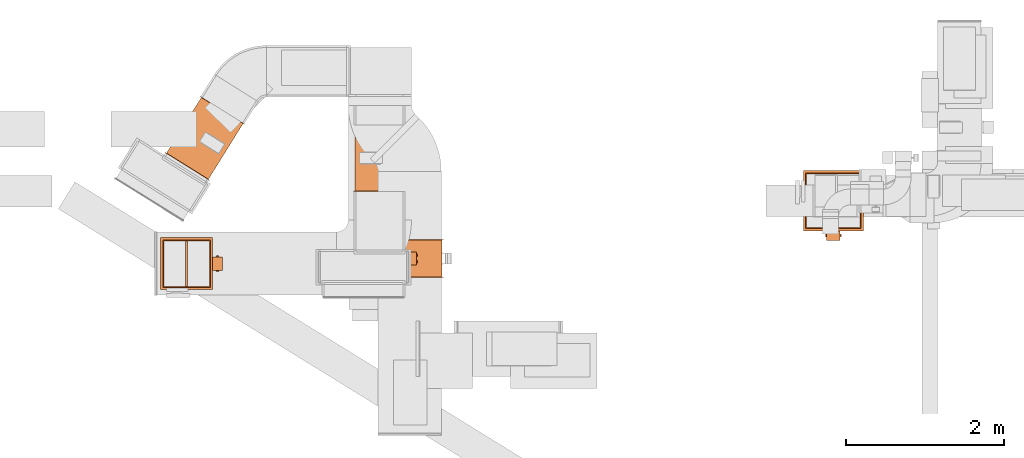
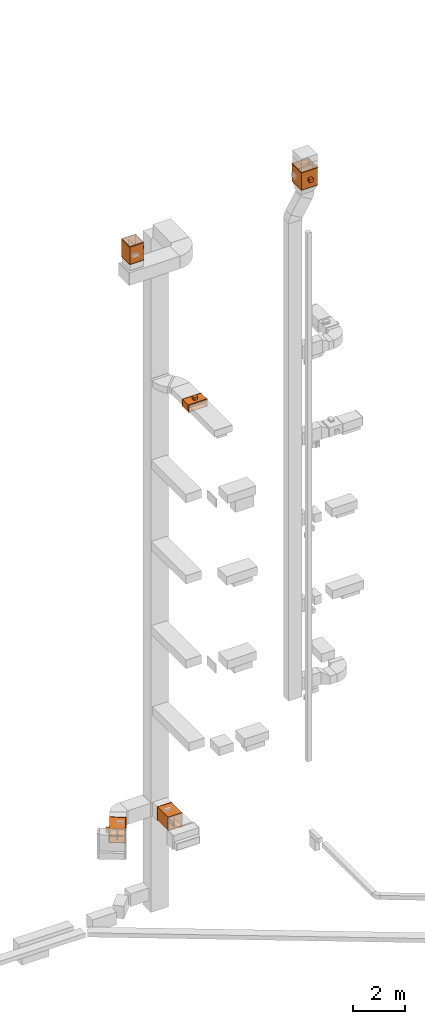
# One storey, part 19 of 29: 5 proxies.
"""IFC2X3 building model written with IfcOpenShell, lengths in millimetres."""

from ifc_helpers import new_model, entity, si_unit, converted_unit, derived_unit, direction, frame, frame_2d, origin, origin_2d_with_axis, place, context, subcontext, project, spatial, polyline, rectangle, hollow_circle, outline, extrude, source, transform, mapped, material, material_list, type_object, type_shapes, element, save


model = new_model("IFC2X3")

# Units and contexts
model_context = context("Model", 3, precision=0.01, world=origin(), true_north=direction((6.12303176911189e-17, 1.0)))
body_context = subcontext(model_context, "Body", "Model", "MODEL_VIEW")
ifc_project = project(units=[si_unit("LENGTHUNIT", "METRE", prefix="MILLI"), si_unit("AREAUNIT", "SQUARE_METRE"), si_unit("VOLUMEUNIT", "CUBIC_METRE"), converted_unit("PLANEANGLEUNIT", "DEGREE", entity("IfcRatioMeasure", 0.0174532925199433), si_unit("PLANEANGLEUNIT", "RADIAN"), dimensions=[0, 0, 0, 0, 0, 0, 0]), si_unit("MASSUNIT", "GRAM", prefix="KILO"), derived_unit("MASSDENSITYUNIT", [(si_unit("MASSUNIT", "GRAM", prefix="KILO"), 1), (si_unit("LENGTHUNIT", "METRE"), -3)]), derived_unit("MOMENTOFINERTIAUNIT", [(si_unit("LENGTHUNIT", "METRE"), 4)]), si_unit("TIMEUNIT", "SECOND"), si_unit("FREQUENCYUNIT", "HERTZ"), si_unit("THERMODYNAMICTEMPERATUREUNIT", "DEGREE_CELSIUS"), derived_unit("THERMALTRANSMITTANCEUNIT", [(si_unit("MASSUNIT", "GRAM", prefix="KILO"), 1), (si_unit("THERMODYNAMICTEMPERATUREUNIT", "KELVIN"), -1), (si_unit("TIMEUNIT", "SECOND"), -3)]), derived_unit("VOLUMETRICFLOWRATEUNIT", [(si_unit("LENGTHUNIT", "METRE"), 3), (si_unit("TIMEUNIT", "SECOND"), -1)]), derived_unit("MASSFLOWRATEUNIT", [(si_unit("MASSUNIT", "GRAM", prefix="KILO"), 1), (si_unit("TIMEUNIT", "SECOND"), -1)]), derived_unit("ROTATIONALFREQUENCYUNIT", [(si_unit("TIMEUNIT", "SECOND"), -1)]), si_unit("ELECTRICCURRENTUNIT", "AMPERE"), si_unit("ELECTRICVOLTAGEUNIT", "VOLT"), si_unit("POWERUNIT", "WATT"), si_unit("FORCEUNIT", "NEWTON", prefix="KILO"), si_unit("ILLUMINANCEUNIT", "LUX"), si_unit("LUMINOUSFLUXUNIT", "LUMEN"), si_unit("LUMINOUSINTENSITYUNIT", "CANDELA"), derived_unit("USERDEFINED", [(si_unit("MASSUNIT", "GRAM", prefix="KILO"), -1), (si_unit("LENGTHUNIT", "METRE"), -2), (si_unit("TIMEUNIT", "SECOND"), 3), (si_unit("LUMINOUSFLUXUNIT", "LUMEN"), 1)]), derived_unit("LINEARVELOCITYUNIT", [(si_unit("LENGTHUNIT", "METRE"), 1), (si_unit("TIMEUNIT", "SECOND"), -1)]), si_unit("PRESSUREUNIT", "PASCAL"), derived_unit("USERDEFINED", [(si_unit("LENGTHUNIT", "METRE"), -2), (si_unit("MASSUNIT", "GRAM", prefix="KILO"), 1), (si_unit("TIMEUNIT", "SECOND"), -2)]), derived_unit("LINEARFORCEUNIT", [(si_unit("MASSUNIT", "GRAM", prefix="KILO"), 1), (si_unit("LENGTHUNIT", "METRE"), 1), (si_unit("TIMEUNIT", "SECOND"), -2), (si_unit("LENGTHUNIT", "METRE"), -1)]), derived_unit("PLANARFORCEUNIT", [(si_unit("MASSUNIT", "GRAM", prefix="KILO"), 1), (si_unit("LENGTHUNIT", "METRE"), 1), (si_unit("TIMEUNIT", "SECOND"), -2), (si_unit("LENGTHUNIT", "METRE"), -2)])], contexts=[model_context])

# Site, building, storey
site_placement = place(None, frame((0.0, -0.00077364408347762, 0.0)))
site = spatial("IfcSite", under=ifc_project, at=site_placement, CompositionType="ELEMENT")
building_placement = place(site_placement, origin())
building = spatial("IfcBuilding", under=site, at=building_placement, CompositionType="ELEMENT")
storey_placement = place(building_placement, origin())
storey = spatial("IfcBuildingStorey", under=building, at=storey_placement, CompositionType="ELEMENT", Elevation=0.0)

# Proxies
ifc_material_1 = material()
ifc_material_2 = material()
ifc_material_list_1 = material_list([ifc_material_1, ifc_material_2])
ifc_material_list_2 = material_list([ifc_material_1, ifc_material_1, ifc_material_1, ifc_material_1, ifc_material_1, ifc_material_1, ifc_material_1, ifc_material_1, ifc_material_1, ifc_material_1, ifc_material_1, ifc_material_1, ifc_material_1, ifc_material_1, ifc_material_2, ifc_material_2, ifc_material_2, ifc_material_2, ifc_material_2])
building_element_proxy_type_1 = type_object("IfcBuildingElementProxyType", PredefinedType="NOTDEFINED", material=ifc_material_list_2)
shared_shape_1 = source(origin(), body_context, "Body", "SweptSolid", [
    extrude(rectangle(XDim=1.5, YDim=170.0, at=frame_2d((3.3806291099836e-14, 0.0), x_axis=(1.0, 0.0))), frame((0.0, -312.750000000076, -62.0), z_axis=(0.0, 0.0, 1.0), x_axis=(0.0, 1.0, 0.0)), (0.0, 0.0, 1.0), 123.000000000001),
    extrude(outline(polyline([(-5.0073597414186, -14.1635201826924), (-3.50735974141928, -14.1635201826924), (-3.50735974141928, 6.32704036539947), (8.51471948283787, 6.3270403654089), (8.51471948283787, 7.83647981728816), (-5.0073597414186, 7.83647981728816), (-5.0073597414186, -14.1635201826924)])), frame((-72.1635201826895, -321.99264025864, -62.0), z_axis=(0.0, 0.0, 1.0), x_axis=(0.0, 1.0, 0.0)), (0.0, 0.0, 1.0), 25.0),
    extrude(outline(polyline([(-13.8364798173165, -5.0073597414188), (7.67295963462824, -5.0073597414188), (7.67295963462824, 8.51471948283767), (6.16352018269341, 8.51471948283767), (6.16352018268311, -3.50735974141901), (-13.8364798173165, -3.50735974141901), (-13.8364798173165, -5.0073597414188)])), frame((72.3270403653872, -321.99264025864, -62.0)), (0.0, 0.0, 1.0), 25.0000000000005),
    extrude(outline(polyline([(-5.00735974141853, -14.163520182702), (-3.50735974141955, -14.163520182702), (-3.50735974141955, 6.3270403653898), (8.51471948283794, 6.32704036538944), (8.51471948283794, 7.83647981731237), (-5.00735974141853, 7.83647981731237), (-5.00735974141853, -14.163520182702)])), frame((-72.1635201826969, -321.99264025864, 36.0), z_axis=(0.0, 0.0, 1.0), x_axis=(0.0, 1.0, 0.0)), (0.0, 0.0, 1.0), 25.0),
    extrude(outline(polyline([(-9.39005042212508, -16.0890911238457), (8.81483867126946, -16.0890911238457), (18.3453872917851, -0.0836606621788136), (9.67104681890716, 15.9217697994894), (-8.95533686966038, 16.1727517860241), (-18.4858854901761, 0.16732132435702), (-9.39005042212508, -16.0890911238457)])), frame((-39.8364798173101, -389.500000000062, 88.0), z_axis=(0.0, 0.0, 1.0), x_axis=(-0.859210135894937, -0.511622851693906, 0.0)), (0.0, 0.0, 1.0), 10.0),
    extrude(outline(polyline([(-9.25778653449053, -16.0349566433433), (9.25778653447247, -16.0349566433433), (18.5155730689534, 0.0), (9.25778653447179, 16.0349566433542), (-9.25778653446304, 16.0349566433379), (-18.515573068944, 0.0), (-9.25778653449053, -16.0349566433433)])), frame((40.0, -389.500000000058, 88.0), z_axis=(0.0, 0.0, 1.0), x_axis=(-0.866025403784451, -0.499999999999978, 0.0)), (0.0, 0.0, 1.0), 10.0),
    extrude(hollow_circle(Radius=15.0, WallThickness=6.97527274236894, at=frame_2d((3.55257043274876e-28, -6.76791955811494e-14), x_axis=(1.0, 0.0))), frame((40.0, -389.500000000057, 86.0)), (0.0, 0.0, 1.0), 14.0),
    extrude(hollow_circle(Radius=15.0, WallThickness=7.0, at=frame_2d((1.00544105397778e-41, -6.76791955811495e-14), x_axis=(1.0, 0.0))), frame((-40.0, -389.500000000057, 86.0)), (0.0, 0.0, 1.0), 14.0),
    extrude(outline(polyline([(-13.8364798173041, -5.0073597414186), (7.67295963460837, -5.0073597414186), (7.67295963460837, 8.51471948283787), (6.16352018269594, 8.51471948283787), (6.1635201826955, -3.50735974141934), (-13.8364798173041, -3.50735974141934), (-13.8364798173041, -5.0073597414186)])), frame((72.3270403653869, -321.99264025864, 36.0)), (0.0, 0.0, 1.0), 25.0),
    extrude(outline(polyline([(-9.39005042212339, -16.0890911238459), (8.81483867127267, -16.0890911238459), (18.345387291786, -0.0836606621774473), (9.67104681890318, 15.9217697994909), (-8.95533686966255, 16.1727517860234), (-18.4858854901759, 0.167321324354905), (-9.39005042212339, -16.0890911238459)])), frame((-39.8364798173151, -389.500000000064, -98.0), z_axis=(0.0, 0.0, 1.0), x_axis=(-0.859210135895013, -0.511622851693778, 0.0)), (0.0, 0.0, 1.0), 9.99999999999999),
    extrude(outline(polyline([(-9.25778653449118, -16.0349566433429), (9.25778653447143, -16.0349566433429), (18.5155730689525, 0.0), (9.25778653447021, 16.0349566433551), (-9.25778653446091, 16.0349566433369), (-18.5155730689421, 0.0), (-9.25778653449118, -16.0349566433429)])), frame((40.0, -389.500000000059, -98.0), z_axis=(0.0, 0.0, 1.0), x_axis=(-0.866025403784445, -0.499999999999988, 0.0)), (0.0, 0.0, 1.0), 9.99999999999999),
    extrude(hollow_circle(Radius=15.0, WallThickness=6.97527274236894, at=frame_2d((1.00544105397778e-41, -6.76791955811495e-14), x_axis=(1.0, 0.0))), frame((40.0, -389.500000000059, -100.0)), (0.0, 0.0, 1.0), 14.0000000000002),
    extrude(hollow_circle(Radius=15.0, WallThickness=7.0, at=frame_2d((1.00544105397778e-41, -6.76791955811495e-14), x_axis=(1.0, 0.0))), frame((-40.0, -389.500000000059, -100.0)), (0.0, 0.0, 1.0), 14.0000000000002),
    extrude(rectangle(XDim=127.0, YDim=159.999999999992, at=frame_2d((0.0, 1.4210854715202e-14), x_axis=(1.0, 0.0))), frame((0.0, -390.500000000059, -86.0), z_axis=(0.0, 0.0, 1.0), x_axis=(0.0, 1.0, 0.0)), (0.0, 0.0, 1.0), 171.999999999999),
    extrude(outline(polyline([(-312.0, -312.0), (312.0, -312.0), (312.0, 312.0), (-312.0, 312.0), (-312.0, -312.0)]), holes=[polyline([(300.0, 300.0), (300.0, -300.0), (-300.0, -300.0), (-300.0, 300.0), (300.0, 300.0)])]), frame((-420.0, 0.0, 0.0), z_axis=(1.0, 0.0, 0.0), x_axis=(0.0, -1.0, 0.0)), (0.0, 0.0, 1.0), 840.0),
    extrude(rectangle(XDim=596.0, YDim=24.0000000000003, at=origin_2d_with_axis()), frame((0.0, 0.0, -288.0), z_axis=(0.0, 0.0, 1.0), x_axis=(-1.0, 0.0, 0.0)), (0.0, 0.0, 1.0), 576.000000000017),
    extrude(outline(polyline([(-330.0, -330.0), (330.0, -330.0), (330.0, 330.0), (-330.0, 330.0), (-330.0, -330.0)]), holes=[polyline([(-300.0, -300.0), (-300.0, 300.0), (300.0, 300.0), (300.0, -300.0), (-300.0, -300.0)])]), frame((415.0, 0.0, 0.0), z_axis=(1.0, 0.0, 0.0), x_axis=(0.0, -1.0, 0.0)), (0.0, 0.0, 1.0), 5.00000000000326),
    extrude(outline(polyline([(-330.0, -330.0), (330.0, -330.0), (330.0, 330.0), (-330.0, 330.0), (-330.0, -330.0)]), holes=[polyline([(-300.0, -300.0), (-300.0, 300.0), (300.0, 300.0), (300.0, -300.0), (-300.0, -300.0)])]), frame((-420.0, 0.0, 0.0), z_axis=(1.0, 0.0, 0.0), x_axis=(0.0, -1.0, 0.0)), (0.0, 0.0, 1.0), 4.99999999999995),
    extrude(outline(polyline([(-300.0, -300.0), (300.0, -300.0), (300.0, 300.0), (-300.0, 300.0), (-300.0, -300.0)]), holes=[polyline([(288.0, -288.0), (-288.0, -288.0), (-288.0, 288.0), (288.0, 288.0), (288.0, -288.0)])]), frame((-6.0, 0.0, 0.0), z_axis=(1.0, 0.0, 0.0), x_axis=(0.0, 0.0, -1.0)), (0.0, 0.0, 1.0), 12.0),
])
type_shapes(building_element_proxy_type_1, [shared_shape_1])
proxy_1_placement = place(storey_placement, frame((4538.73846384672, 15211.3442907761, 2800.0), z_axis=(0.0, 0.0, 1.0), x_axis=(0.0, 1.0, 0.0)))
element("IfcBuildingElementProxy", 1, at=proxy_1_placement, inside=storey, type_object=building_element_proxy_type_1, material=ifc_material_list_1, context=body_context, shape_type="MappedRepresentation", body=[
    mapped(shared_shape_1, transform((0.0, 0.0, 0.0), scale=1.0)),
])
ifc_material_list_3 = material_list([ifc_material_1, ifc_material_2])
proxy_2_placement = place(storey_placement, frame((2329.12093080707, 15461.7090414809, 2785.0), z_axis=(0.0, 0.0, 1.0), x_axis=(-0.529919264328233, -0.848048096097046, 0.0)))
element("IfcBuildingElementProxy", 2, at=proxy_2_placement, inside=storey, type_object=building_element_proxy_type_1, material=ifc_material_list_3, context=body_context, shape_type="MappedRepresentation", body=[
    mapped(shared_shape_1, transform((0.0, 0.0, 0.0), scale=1.0)),
])
ifc_material_list_4 = material_list([ifc_material_1, ifc_material_2])
proxy_3_placement = place(storey_placement, frame((2099.0, 13877.5681314502, 31335.0), z_axis=(0.0, -1.0, 0.0), x_axis=(0.0, 0.0, 1.0)))
element("IfcBuildingElementProxy", 3, at=proxy_3_placement, inside=storey, type_object=building_element_proxy_type_1, material=ifc_material_list_4, context=body_context, shape_type="MappedRepresentation", body=[
    mapped(shared_shape_1, transform((0.0, 0.0, 0.0), scale=1.0)),
])
ifc_material_list_5 = material_list([ifc_material_1, ifc_material_2])
ifc_material_list_6 = material_list([ifc_material_1, ifc_material_1, ifc_material_1, ifc_material_1, ifc_material_1, ifc_material_1, ifc_material_1, ifc_material_1, ifc_material_1, ifc_material_1, ifc_material_1, ifc_material_1, ifc_material_1, ifc_material_1, ifc_material_2, ifc_material_2, ifc_material_2, ifc_material_2, ifc_material_2])
building_element_proxy_type_2 = type_object("IfcBuildingElementProxyType", PredefinedType="NOTDEFINED", material=ifc_material_list_6)
shared_shape_2 = source(origin(), body_context, "Body", "SweptSolid", [
    extrude(rectangle(XDim=1.5, YDim=170.0, at=origin_2d_with_axis()), frame((0.0, -162.750000000076, -62.0), z_axis=(0.0, 0.0, 1.0), x_axis=(0.0, 1.0, 0.0)), (0.0, 0.0, 1.0), 123.000000000001),
    extrude(outline(polyline([(-5.0073597414186, -14.1635201826924), (-3.50735974141924, -14.1635201826924), (-3.50735974141928, 6.32704036539947), (8.51471948283784, 6.3270403654089), (8.51471948283784, 7.83647981728816), (-5.0073597414186, 7.83647981728816), (-5.0073597414186, -14.1635201826924)])), frame((-72.1635201826895, -171.99264025864, -62.0), z_axis=(0.0, 0.0, 1.0), x_axis=(0.0, 1.0, 0.0)), (0.0, 0.0, 1.0), 25.0),
    extrude(outline(polyline([(-13.8364798173165, -5.0073597414188), (7.67295963462824, -5.0073597414188), (7.67295963462824, 8.51471948283767), (6.16352018269341, 8.51471948283767), (6.16352018268311, -3.50735974141897), (-13.8364798173165, -3.50735974141897), (-13.8364798173165, -5.0073597414188)])), frame((72.3270403653872, -171.99264025864, -62.0)), (0.0, 0.0, 1.0), 25.0000000000005),
    extrude(outline(polyline([(-5.00735974141846, -14.163520182702), (-3.50735974141948, -14.163520182702), (-3.50735974141948, 6.3270403653898), (8.51471948283798, 6.32704036538944), (8.51471948283798, 7.83647981731237), (-5.00735974141846, 7.83647981731237), (-5.00735974141846, -14.163520182702)])), frame((-72.1635201826969, -171.99264025864, 36.0), z_axis=(0.0, 0.0, 1.0), x_axis=(0.0, 1.0, 0.0)), (0.0, 0.0, 1.0), 25.0),
    extrude(outline(polyline([(-9.3900504221251, -16.0890911238458), (8.81483867126944, -16.0890911238458), (18.3453872917851, -0.0836606621788432), (9.67104681890714, 15.9217697994894), (-8.95533686966039, 16.172751786024), (-18.4858854901761, 0.167321324356992), (-9.3900504221251, -16.0890911238458)])), frame((-39.8364798173101, -239.500000000062, 88.0), z_axis=(0.0, 0.0, 1.0), x_axis=(-0.859210135894937, -0.511622851693906, 0.0)), (0.0, 0.0, 1.0), 10.0),
    extrude(outline(polyline([(-9.25778653449057, -16.0349566433433), (9.25778653447244, -16.0349566433433), (18.5155730689534, 0.0), (9.25778653447179, 16.0349566433541), (-9.25778653446303, 16.0349566433379), (-18.515573068944, 0.0), (-9.25778653449057, -16.0349566433433)])), frame((40.0, -239.500000000058, 88.0), z_axis=(0.0, 0.0, 1.0), x_axis=(-0.86602540378445, -0.499999999999979, 0.0)), (0.0, 0.0, 1.0), 10.0),
    extrude(hollow_circle(Radius=15.0, WallThickness=6.97527274236894, at=frame_2d((3.55257043274876e-28, -6.76791955811494e-14), x_axis=(1.0, 0.0))), frame((40.0, -239.500000000057, 86.0)), (0.0, 0.0, 1.0), 14.0),
    extrude(hollow_circle(Radius=15.0, WallThickness=7.0, at=frame_2d((1.00544105397778e-41, -6.76791955811495e-14), x_axis=(1.0, 0.0))), frame((-40.0, -239.500000000057, 86.0)), (0.0, 0.0, 1.0), 14.0),
    extrude(outline(polyline([(-13.8364798173041, -5.0073597414186), (7.67295963460837, -5.0073597414186), (7.67295963460837, 8.51471948283787), (6.16352018269594, 8.51471948283787), (6.1635201826955, -3.50735974141934), (-13.8364798173041, -3.50735974141934), (-13.8364798173041, -5.0073597414186)])), frame((72.3270403653869, -171.99264025864, 36.0)), (0.0, 0.0, 1.0), 25.0),
    extrude(outline(polyline([(-9.39005042212341, -16.0890911238458), (8.81483867127266, -16.0890911238458), (18.3453872917859, -0.0836606621775066), (9.67104681890322, 15.9217697994909), (-8.95533686966253, 16.1727517860234), (-18.4858854901759, 0.167321324354935), (-9.39005042212341, -16.0890911238458)])), frame((-39.8364798173151, -239.500000000064, -98.0), z_axis=(0.0, 0.0, 1.0), x_axis=(-0.859210135895012, -0.511622851693779, 0.0)), (0.0, 0.0, 1.0), 9.99999999999999),
    extrude(outline(polyline([(-9.25778653449123, -16.0349566433429), (9.2577865344714, -16.0349566433429), (18.5155730689525, 0.0), (9.25778653447022, 16.034956643355), (-9.25778653446088, 16.0349566433369), (-18.5155730689421, 0.0), (-9.25778653449123, -16.0349566433429)])), frame((40.0, -239.500000000059, -98.0), z_axis=(0.0, 0.0, 1.0), x_axis=(-0.866025403784445, -0.49999999999999, 0.0)), (0.0, 0.0, 1.0), 9.99999999999999),
    extrude(hollow_circle(Radius=15.0, WallThickness=6.97527274236894, at=frame_2d((-3.55257043274856e-28, -6.76791955811497e-14), x_axis=(1.0, 0.0))), frame((40.0, -239.500000000059, -100.0)), (0.0, 0.0, 1.0), 14.0000000000002),
    extrude(hollow_circle(Radius=15.0, WallThickness=7.0, at=frame_2d((1.00544105397778e-41, -6.76791955811495e-14), x_axis=(1.0, 0.0))), frame((-40.0, -239.500000000059, -100.0)), (0.0, 0.0, 1.0), 14.0000000000002),
    extrude(rectangle(XDim=127.0, YDim=159.999999999992, at=frame_2d((0.0, 1.4210854715202e-14), x_axis=(1.0, 0.0))), frame((0.0, -240.500000000059, -86.0), z_axis=(0.0, 0.0, 1.0), x_axis=(0.0, 1.0, 0.0)), (0.0, 0.0, 1.0), 171.999999999999),
    extrude(outline(polyline([(-162.0, -412.0), (162.0, -412.0), (162.0, 412.0), (-162.0, 412.0), (-162.0, -412.0)]), holes=[polyline([(150.0, 400.0), (150.0, -400.0), (-150.0, -400.0), (-150.0, 400.0), (150.0, 400.0)])]), frame((-240.0, 0.0, 0.0), z_axis=(1.0, 0.0, 0.0), x_axis=(0.0, -1.0, 0.0)), (0.0, 0.0, 1.0), 480.0),
    extrude(rectangle(XDim=296.0, YDim=24.0000000000003, at=origin_2d_with_axis()), frame((0.0, 0.0, -388.0), z_axis=(0.0, 0.0, 1.0), x_axis=(-1.0, 0.0, 0.0)), (0.0, 0.0, 1.0), 776.000000000017),
    extrude(outline(polyline([(-180.0, -430.0), (180.0, -430.0), (180.0, 430.0), (-180.0, 430.0), (-180.0, -430.0)]), holes=[polyline([(-150.0, -400.0), (-150.0, 400.0), (150.0, 400.0), (150.0, -400.0), (-150.0, -400.0)])]), frame((235.0, 0.0, 0.0), z_axis=(1.0, 0.0, 0.0), x_axis=(0.0, -1.0, 0.0)), (0.0, 0.0, 1.0), 5.00000000000319),
    extrude(outline(polyline([(-180.0, -430.0), (180.0, -430.0), (180.0, 430.0), (-180.0, 430.0), (-180.0, -430.0)]), holes=[polyline([(-150.0, -400.0), (-150.0, 400.0), (150.0, 400.0), (150.0, -400.0), (-150.0, -400.0)])]), frame((-240.0, 0.0, 0.0), z_axis=(1.0, 0.0, 0.0), x_axis=(0.0, -1.0, 0.0)), (0.0, 0.0, 1.0), 4.99999999999991),
    extrude(outline(polyline([(-400.0, -150.0), (400.0, -150.0), (400.0, 150.0), (-400.0, 150.0), (-400.0, -150.0)]), holes=[polyline([(388.0, -138.0), (-388.0, -138.0), (-388.0, 138.0), (388.0, 138.0), (388.0, -138.0)])]), frame((-6.0, 0.0, 0.0), z_axis=(1.0, 0.0, 0.0), x_axis=(0.0, 0.0, -1.0)), (0.0, 0.0, 1.0), 12.0),
])
type_shapes(building_element_proxy_type_2, [shared_shape_2])
proxy_4_placement = place(storey_placement, frame((4919.66175990126, 13941.6087465571, 23050.0), z_axis=(1.0, 0.0, 0.0), x_axis=(0.0, -1.0, 0.0)))
element("IfcBuildingElementProxy", 4, at=proxy_4_placement, inside=storey, type_object=building_element_proxy_type_2, material=ifc_material_list_5, context=body_context, shape_type="MappedRepresentation", body=[
    mapped(shared_shape_2, transform((0.0, 0.0, 0.0), scale=1.0)),
])
ifc_material_list_7 = material_list([ifc_material_1, ifc_material_2])
ifc_material_list_8 = material_list([ifc_material_1, ifc_material_1, ifc_material_1, ifc_material_1, ifc_material_1, ifc_material_1, ifc_material_1, ifc_material_1, ifc_material_1, ifc_material_1, ifc_material_1, ifc_material_1, ifc_material_1, ifc_material_1, ifc_material_2, ifc_material_2, ifc_material_2, ifc_material_2, ifc_material_2])
building_element_proxy_type_3 = type_object("IfcBuildingElementProxyType", PredefinedType="NOTDEFINED", material=ifc_material_list_8)
shared_shape_3 = source(origin(), body_context, "Body", "SweptSolid", [
    extrude(rectangle(XDim=1.5, YDim=170.0, at=frame_2d((3.3806291099836e-14, 0.0), x_axis=(1.0, 0.0))), frame((0.0, -362.750000000075, -62.0), z_axis=(0.0, 0.0, 1.0), x_axis=(0.0, 1.0, 0.0)), (0.0, 0.0, 1.0), 123.000000000001),
    extrude(outline(polyline([(-5.00735974141867, -14.1635201826924), (-3.50735974141934, -14.1635201826924), (-3.50735974141934, 6.32704036539947), (8.51471948283781, 6.3270403654089), (8.51471948283781, 7.83647981728816), (-5.00735974141867, 7.83647981728816), (-5.00735974141867, -14.1635201826924)])), frame((-72.1635201826895, -371.99264025864, -62.0), z_axis=(0.0, 0.0, 1.0), x_axis=(0.0, 1.0, 0.0)), (0.0, 0.0, 1.0), 25.0),
    extrude(outline(polyline([(-13.8364798173165, -5.0073597414188), (7.67295963462824, -5.0073597414188), (7.67295963462824, 8.51471948283767), (6.16352018269341, 8.51471948283767), (6.16352018268311, -3.50735974141901), (-13.8364798173165, -3.50735974141901), (-13.8364798173165, -5.0073597414188)])), frame((72.3270403653872, -371.99264025864, -62.0)), (0.0, 0.0, 1.0), 25.0000000000005),
    extrude(outline(polyline([(-5.00735974141853, -14.163520182702), (-3.50735974141955, -14.163520182702), (-3.50735974141955, 6.3270403653898), (8.51471948283794, 6.32704036538944), (8.51471948283794, 7.83647981731237), (-5.00735974141853, 7.83647981731237), (-5.00735974141853, -14.163520182702)])), frame((-72.1635201826969, -371.99264025864, 36.0), z_axis=(0.0, 0.0, 1.0), x_axis=(0.0, 1.0, 0.0)), (0.0, 0.0, 1.0), 25.0),
    extrude(outline(polyline([(-9.39005042212508, -16.0890911238457), (8.81483867126946, -16.0890911238457), (18.3453872917851, -0.0836606621788136), (9.67104681890716, 15.9217697994894), (-8.95533686966038, 16.1727517860241), (-18.4858854901761, 0.16732132435702), (-9.39005042212508, -16.0890911238457)])), frame((-39.8364798173101, -439.500000000061, 88.0), z_axis=(0.0, 0.0, 1.0), x_axis=(-0.859210135894937, -0.511622851693906, 0.0)), (0.0, 0.0, 1.0), 9.99999999999999),
    extrude(outline(polyline([(-9.25778653449053, -16.0349566433433), (9.25778653447247, -16.0349566433433), (18.5155730689534, 0.0), (9.25778653447179, 16.0349566433542), (-9.25778653446304, 16.0349566433379), (-18.515573068944, 0.0), (-9.25778653449053, -16.0349566433433)])), frame((40.0, -439.500000000057, 88.0), z_axis=(0.0, 0.0, 1.0), x_axis=(-0.866025403784451, -0.499999999999978, 0.0)), (0.0, 0.0, 1.0), 9.99999999999999),
    extrude(hollow_circle(Radius=15.0, WallThickness=6.97527274236894, at=frame_2d((3.55257043274876e-28, -6.76791955811494e-14), x_axis=(1.0, 0.0))), frame((40.0, -439.500000000057, 86.0)), (0.0, 0.0, 1.0), 14.0),
    extrude(hollow_circle(Radius=15.0, WallThickness=7.0, at=frame_2d((1.00544105397778e-41, -6.76791955811495e-14), x_axis=(1.0, 0.0))), frame((-40.0, -439.500000000057, 86.0)), (0.0, 0.0, 1.0), 14.0),
    extrude(outline(polyline([(-13.8364798173041, -5.0073597414186), (7.67295963460837, -5.0073597414186), (7.67295963460837, 8.51471948283787), (6.16352018269594, 8.51471948283787), (6.1635201826955, -3.50735974141934), (-13.8364798173041, -3.50735974141934), (-13.8364798173041, -5.0073597414186)])), frame((72.3270403653869, -371.992640258639, 36.0)), (0.0, 0.0, 1.0), 25.0),
    extrude(outline(polyline([(-9.39005042212335, -16.0890911238458), (8.8148386712727, -16.0890911238458), (18.345387291786, -0.0836606621773892), (9.67104681890321, 15.9217697994909), (-8.95533686966252, 16.1727517860234), (-18.4858854901758, 0.167321324354963), (-9.39005042212335, -16.0890911238458)])), frame((-39.8364798173151, -439.500000000063, -98.0), z_axis=(0.0, 0.0, 1.0), x_axis=(-0.859210135895013, -0.511622851693778, 0.0)), (0.0, 0.0, 1.0), 9.99999999999999),
    extrude(outline(polyline([(-9.25778653449122, -16.034956643343), (9.25778653447139, -16.034956643343), (18.5155730689525, 0.0), (9.25778653447017, 16.034956643355), (-9.25778653446094, 16.0349566433368), (-18.5155730689421, 0.0), (-9.25778653449122, -16.034956643343)])), frame((40.0, -439.500000000059, -98.0), z_axis=(0.0, 0.0, 1.0), x_axis=(-0.866025403784445, -0.499999999999988, 0.0)), (0.0, 0.0, 1.0), 9.99999999999999),
    extrude(hollow_circle(Radius=15.0, WallThickness=6.97527274236894, at=frame_2d((-3.55257043274856e-28, -6.76791955811497e-14), x_axis=(1.0, 0.0))), frame((40.0, -439.500000000059, -100.0)), (0.0, 0.0, 1.0), 14.0000000000002),
    extrude(hollow_circle(Radius=15.0, WallThickness=7.0, at=frame_2d((1.00544105397778e-41, -6.76791955811495e-14), x_axis=(1.0, 0.0))), frame((-40.0, -439.500000000059, -100.0)), (0.0, 0.0, 1.0), 14.0000000000002),
    extrude(rectangle(XDim=127.0, YDim=159.999999999992, at=frame_2d((0.0, 1.4210854715202e-14), x_axis=(1.0, 0.0))), frame((0.0, -440.500000000059, -86.0), z_axis=(0.0, 0.0, 1.0), x_axis=(0.0, 1.0, 0.0)), (0.0, 0.0, 1.0), 171.999999999999),
    extrude(outline(polyline([(-362.0, -362.0), (362.0, -362.0), (362.0, 362.0), (-362.0, 362.0), (-362.0, -362.0)]), holes=[polyline([(350.0, 350.0), (350.0, -350.0), (-350.0, -350.0), (-350.0, 350.0), (350.0, 350.0)])]), frame((-420.0, 0.0, 0.0), z_axis=(1.0, 0.0, 0.0), x_axis=(0.0, -1.0, 0.0)), (0.0, 0.0, 1.0), 840.0),
    extrude(rectangle(XDim=696.0, YDim=24.0000000000003, at=origin_2d_with_axis()), frame((0.0, 0.0, -338.0), z_axis=(0.0, 0.0, 1.0), x_axis=(-1.0, 0.0, 0.0)), (0.0, 0.0, 1.0), 676.000000000017),
    extrude(outline(polyline([(-380.0, -380.0), (380.0, -380.0), (380.0, 380.0), (-380.0, 380.0), (-380.0, -380.0)]), holes=[polyline([(-350.0, -350.0), (-350.0, 350.0), (350.0, 350.0), (350.0, -350.0), (-350.0, -350.0)])]), frame((415.0, 0.0, 0.0), z_axis=(1.0, 0.0, 0.0), x_axis=(0.0, -1.0, 0.0)), (0.0, 0.0, 1.0), 5.00000000000326),
    extrude(outline(polyline([(-380.0, -380.0), (380.0, -380.0), (380.0, 380.0), (-380.0, 380.0), (-380.0, -380.0)]), holes=[polyline([(-350.0, -350.0), (-350.0, 350.0), (350.0, 350.0), (350.0, -350.0), (-350.0, -350.0)])]), frame((-420.0, 0.0, 0.0), z_axis=(1.0, 0.0, 0.0), x_axis=(0.0, -1.0, 0.0)), (0.0, 0.0, 1.0), 4.99999999999995),
    extrude(outline(polyline([(-350.0, -350.0), (350.0, -350.0), (350.0, 350.0), (-350.0, 350.0), (-350.0, -350.0)]), holes=[polyline([(338.0, -338.0), (-338.0, -338.0), (-338.0, 338.0), (338.0, 338.0), (338.0, -338.0)])]), frame((-6.0, 0.0, 0.0), z_axis=(1.0, 0.0, 0.0), x_axis=(0.0, 0.0, -1.0)), (0.0, 0.0, 1.0), 12.0),
])
type_shapes(building_element_proxy_type_3, [shared_shape_3])
proxy_5_placement = place(storey_placement, frame((10279.7340134019, 14672.5640511154, 31560.0), z_axis=(-1.0, 0.0, 0.0), x_axis=(0.0, 0.0, 1.0)))
element("IfcBuildingElementProxy", 5, at=proxy_5_placement, inside=storey, type_object=building_element_proxy_type_3, material=ifc_material_list_7, context=body_context, shape_type="MappedRepresentation", body=[
    mapped(shared_shape_3, transform((0.0, 0.0, 0.0), scale=1.0)),
])

save(model, "model.ifc")
